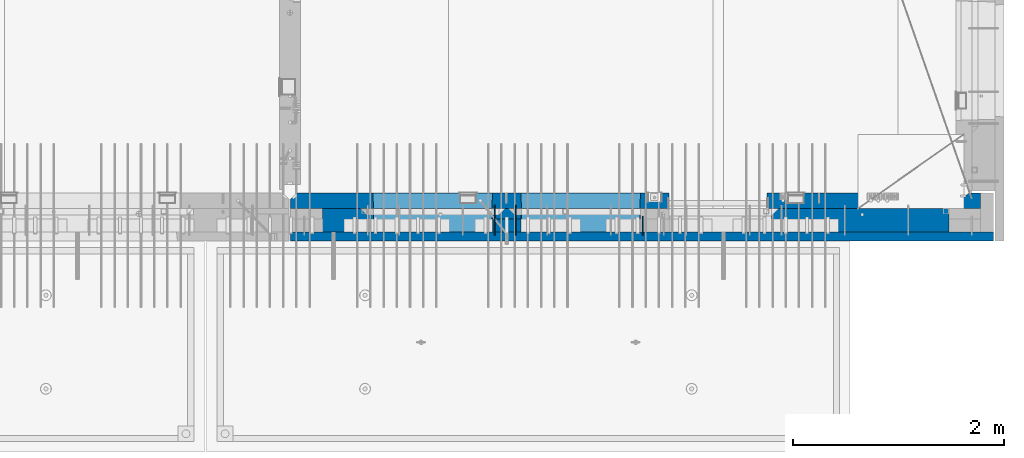
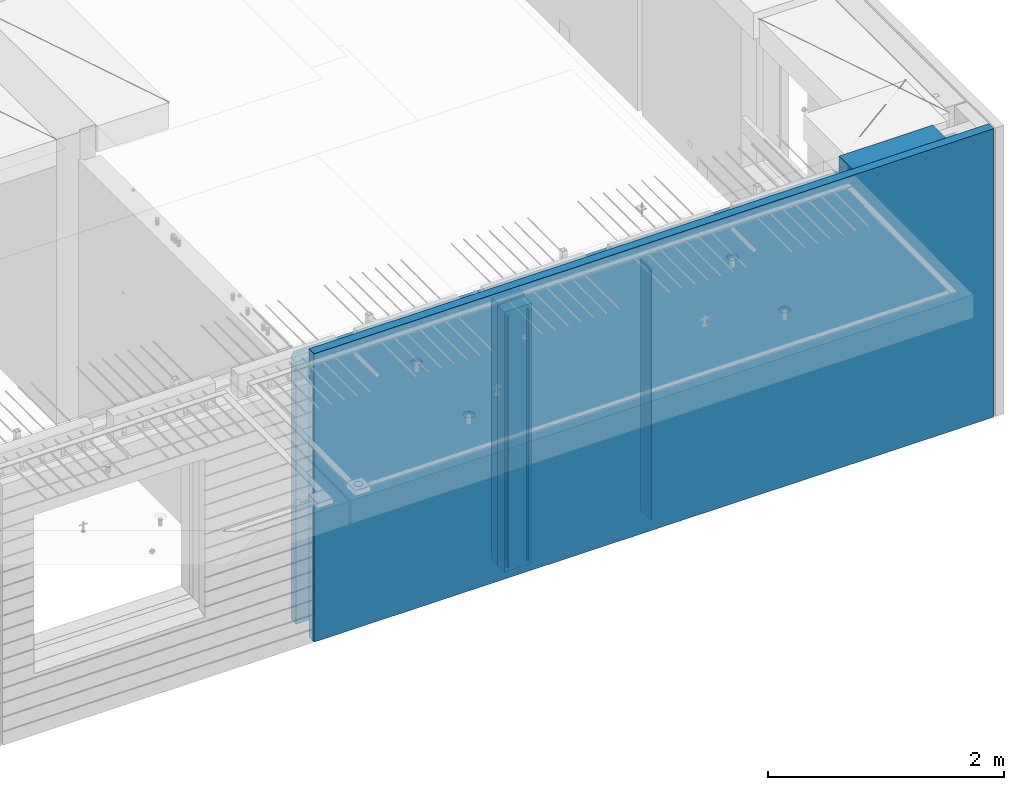
# One storey, part 234 of 352: 8 walls, 1 element without a shape of its own.
"""IFC2X3 building model written with IfcOpenShell, lengths in millimetres."""

from ifc_helpers import new_model, si_unit, frame, origin_with_axes, place, context, subcontext, project, spatial, faceted_brep, material, type_object, element, aggregate, save


model = new_model("IFC2X3")

# Units and contexts
model_context = context("Model", 3, precision=1e-05, world=origin_with_axes())
body_context = subcontext(model_context, "Body", "Model", "MODEL_VIEW")
ifc_project = project(units=[si_unit("LENGTHUNIT", "METRE", prefix="MILLI"), si_unit("AREAUNIT", "SQUARE_METRE"), si_unit("VOLUMEUNIT", "CUBIC_METRE"), si_unit("MASSUNIT", "GRAM", prefix="KILO"), si_unit("TIMEUNIT", "SECOND"), si_unit("PLANEANGLEUNIT", "RADIAN"), si_unit("SOLIDANGLEUNIT", "STERADIAN"), si_unit("THERMODYNAMICTEMPERATUREUNIT", "DEGREE_CELSIUS"), si_unit("LUMINOUSINTENSITYUNIT", "LUMEN")], contexts=[model_context])

# Site, building, storey
site_placement = place(None, origin_with_axes())
site = spatial("IfcSite", under=ifc_project, at=site_placement, CompositionType="ELEMENT")
building_placement = place(site_placement, origin_with_axes())
building = spatial("IfcBuilding", under=site, at=building_placement, CompositionType="ELEMENT")
storey_placement = place(building_placement, origin_with_axes())
storey = spatial("IfcBuildingStorey", under=building, at=storey_placement, Name="6", CompositionType="ELEMENT", Elevation=0.0)

# Assembly, walls
assembly_placement = place(storey_placement, origin_with_axes())
assembly = element("IfcElementAssembly", 1, at=assembly_placement, inside=storey, AssemblyPlace="NOTDEFINED", PredefinedType="REINFORCEMENT_UNIT")
ifc_material_1 = material(Name="Undefined")
wall_type_1 = type_object("IfcWallType", PredefinedType="NOTDEFINED")
wall_1_placement = place(assembly_placement, frame((31944.9998946285, 7780.0, 98115.0), z_axis=(0.0, 0.0, 1.0), x_axis=(0.0, -1.0, 0.0)))
wall_1 = element("IfcWall", 2, at=wall_1_placement, type_object=wall_type_1, material=ifc_material_1, Name="(PD)", context=body_context, shape_type="Brep", body=[
    faceted_brep([(0.0, 5.0, -1300.0), (0.0, 5.0, 1300.0), (180.0, 5.0, 1300.0), (180.0, 5.0, -1300.0), (0.0, -5.0, 1300.0), (180.0, -5.0, 1300.0), (0.0, -5.0, -1300.0), (180.0, -5.0, -1300.0)], [[[0, 1, 2, 3]], [[1, 4, 5, 2]], [[4, 6, 7, 5]], [[6, 0, 3, 7]], [[5, 7, 3, 2]], [[6, 4, 1, 0]]]),
])
wall_2_placement = place(assembly_placement, frame((30545.0021834468, 7880.0, 98115.0), z_axis=(0.0, 0.0, 1.0), x_axis=(0.0, -1.0, 0.0)))
wall_2 = element("IfcWall", 3, at=wall_2_placement, type_object=wall_type_1, material=ifc_material_1, Name="(PD)", context=body_context, shape_type="Brep", body=[
    faceted_brep([(0.0, 5.0, -1300.0), (0.0, 5.0, 1300.0), (280.0, 5.0, 1300.0), (280.0, 5.0, -1300.0), (0.0, -5.0, 1300.0), (280.0, -5.0, 1300.0), (0.0, -5.0, -1300.0), (280.0, -5.0, -1300.0)], [[[0, 1, 2, 3]], [[1, 4, 5, 2]], [[4, 6, 7, 5]], [[6, 0, 3, 7]], [[5, 7, 3, 2]], [[6, 4, 1, 0]]]),
])
wall_3_placement = place(assembly_placement, frame((30745.0021834468, 7880.0, 98115.0), z_axis=(0.0, 0.0, 1.0), x_axis=(0.0, -1.0, 0.0)))
wall_3 = element("IfcWall", 4, at=wall_3_placement, type_object=wall_type_1, material=ifc_material_1, Name="(PD)", context=body_context, shape_type="Brep", body=[
    faceted_brep([(0.0, 5.0, -1300.0), (0.0, 5.0, 1300.0), (280.0, 5.0, 1300.0), (280.0, 5.0, -1300.0), (0.0, -5.0, 1300.0), (280.0, -5.0, 1300.0), (0.0, -5.0, -1300.0), (280.0, -5.0, -1300.0)], [[[0, 1, 2, 3]], [[1, 4, 5, 2]], [[4, 6, 7, 5]], [[6, 0, 3, 7]], [[5, 7, 3, 2]], [[6, 4, 1, 0]]]),
])
ifc_material_2 = material(Name="COS5gt")
wall_type_2 = type_object("IfcWallType", PredefinedType="NOTDEFINED")
wall_4_placement = place(assembly_placement, frame((34845.0, 7740.0, 98247.5), z_axis=(0.0, 0.0, 1.0), x_axis=(-1.0, 3.00000001838171e-08, 0.0)))
wall_4 = element("IfcWall", 5, at=wall_4_placement, type_object=wall_type_2, material=ifc_material_2, context=body_context, shape_type="Brep", body=[
    faceted_brep([(917.0, -110.0, 1492.5), (917.0, -110.0, 1202.5), (917.0, 110.0, 1202.5), (917.0, 110.0, 1492.5), (0.0, 110.0, 1492.5), (0.0, -110.0, 1492.5), (0.0, -110.0, -1492.5), (1680.00110766775, -110.0, -1492.5), (1680.00110766775, -110.0, 857.5), (2649.99996185248, -110.0, 857.5), (2649.99996185248, -110.0, 1202.5), (0.0, 90.0, -1492.5), (1680.00110766775, 90.0, -1492.5), (0.0, 90.0, -1442.5), (1680.00110766775, 90.0, -1442.5), (0.0, 110.0, -1442.5), (1680.00110766775, 110.0, -1442.5), (1680.00110766775, 110.0, 857.5), (2649.99996185248, 110.0, 857.5), (2649.99996185248, -10.0, 857.5), (2649.99996185248, -10.0, 1202.5), (2649.99996185248, 110.0, 1202.5), (4049.99996185248, -10.0, 1202.5), (4049.99996185248, -10.0, -1492.5), (4049.99996185248, 90.0, -1492.5), (4049.99996185248, 90.0, -1442.5), (4049.99996185248, 110.0, -1442.5), (4049.99996185248, 110.0, 1202.5), (2920.0018706072, 110.0, 1202.5), (2920.0018706072, -10.0, 1202.5), (2920.0018706072, -110.0, 1202.5), (4049.99996185248, -110.0, 1202.5), (2920.0018706072, 110.0, -1442.5), (2920.0018706072, 90.0, -1442.5), (2920.0018706072, 90.0, -1492.5), (2920.0018706072, -10.0, -1492.5), (2920.0018706072, -110.0, -1492.5), (4045.94781655315, -110.0, -813.445945945947), (4040.0018706072, 110.0, -807.5), (4010.0018706072, 110.0, -807.5), (2960.0018706072, 110.0, -807.5), (2930.0018706072, 110.0, -807.5), (2924.05592466125, -110.0, -813.445945945947), (4049.99996185248, -110.0, -1492.5), (2924.05592466125, -110.0, 813.445945945947), (4045.94781655315, -110.0, 813.445945945947), (4040.0018706072, 110.0, -802.5), (4040.0018706072, 110.0, 807.5), (2930.0018706072, 110.0, 807.5), (2930.0018706072, 110.0, -802.5), (4320.0018706072, -10.0, 1202.5), (4320.0018706072, 110.0, 1202.5), (4320.0018706072, 110.0, -1442.5), (4320.0018706072, 90.0, -1442.5), (4320.0018706072, 90.0, -1492.5), (4320.0018706072, -10.0, -1492.5), (5928.5, 90.0, -1442.5), (5928.5, 90.0, -1492.5), (5928.5, 110.0, -1442.5), (5928.5, 110.0, -1492.5), (5930.0, -110.0, -1492.5), (5930.0, 110.0, -1492.5), (5930.0, 110.0, 1202.5), (5930.0, -110.0, 1202.5), (4320.0018706072, -110.0, -1492.5), (4320.0018706072, -110.0, 1202.5), (5445.94552773479, -110.0, -813.445945945947), (5439.99958178884, 110.0, -807.5), (5409.99958178884, 110.0, -807.5), (4359.99958178884, 110.0, -807.5), (4329.99958178884, 110.0, -807.5), (4324.05363584289, -110.0, -813.445945945947), (4324.05363584289, -110.0, 813.445945945947), (5445.94552773479, -110.0, 813.445945945947), (5439.99958178884, 110.0, -802.5), (5439.99958178884, 110.0, 807.5), (4329.99958178884, 110.0, 807.5), (4329.99958178884, 110.0, -802.5)], [[[0, 1, 2, 3]], [[4, 5, 0, 3]], [[1, 0, 5, 6, 7, 8, 9, 10]], [[6, 11, 12, 7]], [[11, 13, 14, 12]], [[11, 6, 5, 4, 15, 13]], [[13, 15, 16, 14]], [[7, 12, 14, 16, 17, 8]], [[8, 17, 18, 19, 9]], [[10, 9, 19, 20]], [[2, 1, 10, 20, 21]], [[17, 16, 15, 4, 3, 2, 21, 18]], [[20, 19, 18, 21]], [[22, 23, 24, 25, 26, 27]], [[28, 29, 30, 31, 22, 27]], [[29, 28, 32, 33, 34, 35]], [[30, 29, 35, 36]], [[37, 38, 39, 40, 41, 42]], [[43, 31, 30, 36], [37, 42, 44, 45]], [[46, 38, 37, 45, 47]], [[44, 48, 47, 45]], [[42, 41, 49, 48, 44]], [[32, 28, 27, 26], [41, 40, 39, 38, 46, 47, 48, 49]], [[33, 32, 26, 25]], [[34, 33, 25, 24]], [[34, 24, 23, 43, 36, 35]], [[31, 43, 23, 22]], [[50, 51, 52, 53, 54, 55]], [[56, 57, 54, 53]], [[58, 56, 53, 52]], [[57, 56, 58, 59]], [[60, 61, 62, 63]], [[54, 57, 59, 61, 60, 64, 55]], [[65, 50, 55, 64]], [[66, 67, 68, 69, 70, 71]], [[60, 63, 65, 64], [66, 71, 72, 73]], [[74, 67, 66, 73, 75]], [[72, 76, 75, 73]], [[71, 70, 77, 76, 72]], [[62, 61, 59, 58, 52, 51], [70, 69, 68, 67, 74, 75, 76, 77]], [[65, 63, 62, 51, 50]]]),
])
ifc_material_3 = material(Name="CONCRETE/C30/37")
wall_type_3 = type_object("IfcWallType", PredefinedType="NOTDEFINED")
wall_5_placement = place(assembly_placement, frame((35265.0, 7587.5, 98247.5), z_axis=(0.0, 0.0, 1.0), x_axis=(-1.0, 3.00000001838171e-08, 0.0)))
wall_5 = element("IfcWall", 6, at=wall_5_placement, type_object=wall_type_3, material=ifc_material_3, context=body_context, shape_type="Brep", body=[
    faceted_brep([(0.0, 42.5, -1492.5), (0.0, 42.5, 1492.5), (6650.0, 42.5, 1492.5), (6650.0, 42.5, -1492.5), (0.0, -42.5, 1492.5), (6650.0, -42.5, 1492.5), (0.0, -42.5, -1492.5), (6650.0, -42.5, -1492.5)], [[[0, 1, 2, 3]], [[1, 4, 5, 2]], [[4, 6, 7, 5]], [[6, 0, 3, 7]], [[5, 7, 3, 2]], [[6, 4, 1, 0]]]),
])
ifc_material_4 = material(Name="CONCRETE/C35/45")
wall_type_4 = type_object("IfcWallType", PredefinedType="NOTDEFINED")
wall_6_placement = place(assembly_placement, frame((35145.0, 7925.0, 98112.5), z_axis=(0.0, 0.0, 1.0), x_axis=(-1.0, 3.00000001838171e-08, 0.0)))
wall_6 = element("IfcWall", 7, at=wall_6_placement, type_object=wall_type_4, material=ifc_material_4, context=body_context, shape_type="Brep", body=[
    faceted_brep([(202.000000451517, -54.9999973486238, 1357.5), (202.000000451517, -54.9999973486238, -1357.5), (214.999999722531, -75.0, -1357.5), (214.999999722531, -75.0, 1357.5), (128.000000410604, -54.9999993903875, 1357.5), (128.000000410604, -54.9999993903875, -1357.5), (115.0, -75.0, 1357.5), (115.0, -75.0, -1357.5), (0.0, -75.0, -1357.5), (0.0, -75.0, 1357.5), (0.0, 75.0, 1357.5), (0.0, 75.0, -1357.5), (6470.0, -75.0, 1357.5), (6530.0, -15.0, 1357.5), (6530.0, 75.0, 1357.5), (6530.0, 75.0, -1357.5), (6530.0, -15.0, -1357.5), (6470.0, -75.0, -1357.5), (2950.00110766775, -75.0, -1357.5), (2946.15495382159, 75.0, -1357.5), (2950.00110766775, -75.0, 952.5), (2946.1549538216, 75.0, 948.653846153844), (2020.00110766775, -75.0, 952.5), (2023.8472615139, 75.0, 948.653846153844), (2020.00110766775, -75.0, -1357.5), (2023.8472615139, 75.0, -1357.5), (5749.99958178884, -75.0, -682.5), (5745.94552773479, 75.0, -678.445945945947), (4624.05363584289, 75.0, -678.445945945947), (4619.99958178884, -75.0, -682.5), (5749.99958178884, -75.0, 952.5), (5745.94552773479, 75.0, 948.445945945947), (4619.99958178884, -75.0, 952.5), (4624.05363584289, 75.0, 948.445945945947), (4345.94781655315, 75.0, -678.445945945947), (4345.94781655315, 75.0, 948.445945945947), (3224.05592466125, 75.0, 948.445945945947), (3224.05592466125, 75.0, -678.445945945947), (3220.0018706072, -75.0, -682.5), (3220.0018706072, -75.0, 952.5), (4350.0018706072, -75.0, -682.5), (4350.0018706072, -75.0, 952.5)], [[[0, 1, 2, 3]], [[4, 5, 1, 0]], [[6, 7, 5, 4]], [[8, 9, 10, 11]], [[0, 3, 12, 13, 14, 10, 9, 6, 4]], [[15, 14, 13, 16]], [[12, 17, 16, 13]], [[15, 16, 17, 18, 19]], [[19, 18, 20, 21]], [[22, 23, 21, 20]], [[24, 25, 23, 22]], [[26, 27, 28, 29]], [[27, 26, 30, 31]], [[32, 33, 31, 30]], [[29, 28, 33, 32]], [[11, 10, 14, 15, 19, 21, 23, 25], [34, 35, 36, 37], [27, 31, 33, 28]], [[38, 37, 36, 39]], [[40, 34, 37, 38]], [[34, 40, 41, 35]], [[39, 36, 35, 41]], [[24, 22, 20, 18, 17, 12, 3, 2], [40, 38, 39, 41], [26, 29, 32, 30]], [[8, 11, 25, 24, 2, 1, 5, 7]], [[9, 8, 7, 6]]]),
])
wall_type_5 = type_object("IfcWallType", PredefinedType="NOTDEFINED")
wall_7_placement = place(assembly_placement, frame((30795.0000381475, 7800.0, 98112.5), z_axis=(0.0, 0.0, 1.0), x_axis=(-1.0, 3.00000001838171e-08, 0.0)))
wall_7 = element("IfcWall", 8, at=wall_7_placement, type_object=wall_type_5, material=ifc_material_4, context=body_context, shape_type="Brep", body=[
    faceted_brep([(0.0, 50.0, -1357.5), (0.0, 50.0, 1357.5), (270.001908754726, 50.0, 1357.5), (270.001908754726, 50.0, -1357.5), (0.0, -50.0, 1357.5), (270.001908754726, -50.0, 1357.5), (0.0, -50.0, -1357.5), (270.001908754726, -50.0, -1357.5)], [[[0, 1, 2, 3]], [[1, 4, 5, 2]], [[4, 6, 7, 5]], [[6, 0, 3, 7]], [[5, 7, 3, 2]], [[6, 4, 1, 0]]]),
])
ifc_material_5 = material(Name="SPU")
wall_type_6 = type_object("IfcWallType", PredefinedType="NOTDEFINED")
wall_8_placement = place(assembly_placement, frame((30795.0000381475, 7690.0, 98102.5), z_axis=(0.0, 0.0, 1.0), x_axis=(-1.0, 3.00000001838171e-08, 0.0)))
wall_8 = element("IfcWall", 9, at=wall_8_placement, type_object=wall_type_6, material=ifc_material_5, context=body_context, shape_type="Brep", body=[
    faceted_brep([(0.0, 60.0, -1347.5), (0.0, 60.0, 1347.5), (270.001908754726, 60.0, 1347.5), (270.001908754726, 60.0, -1347.5), (0.0, -60.0, 1347.5), (270.001908754726, -60.0, 1347.5), (0.0, -60.0, -1347.5), (270.001908754726, -60.0, -1347.5)], [[[0, 1, 2, 3]], [[1, 4, 5, 2]], [[4, 6, 7, 5]], [[6, 0, 3, 7]], [[5, 7, 3, 2]], [[6, 4, 1, 0]]]),
])
aggregate(assembly, [wall_8, wall_7, wall_1, wall_2, wall_3, wall_4, wall_5, wall_6])

save(model, "model.ifc")
